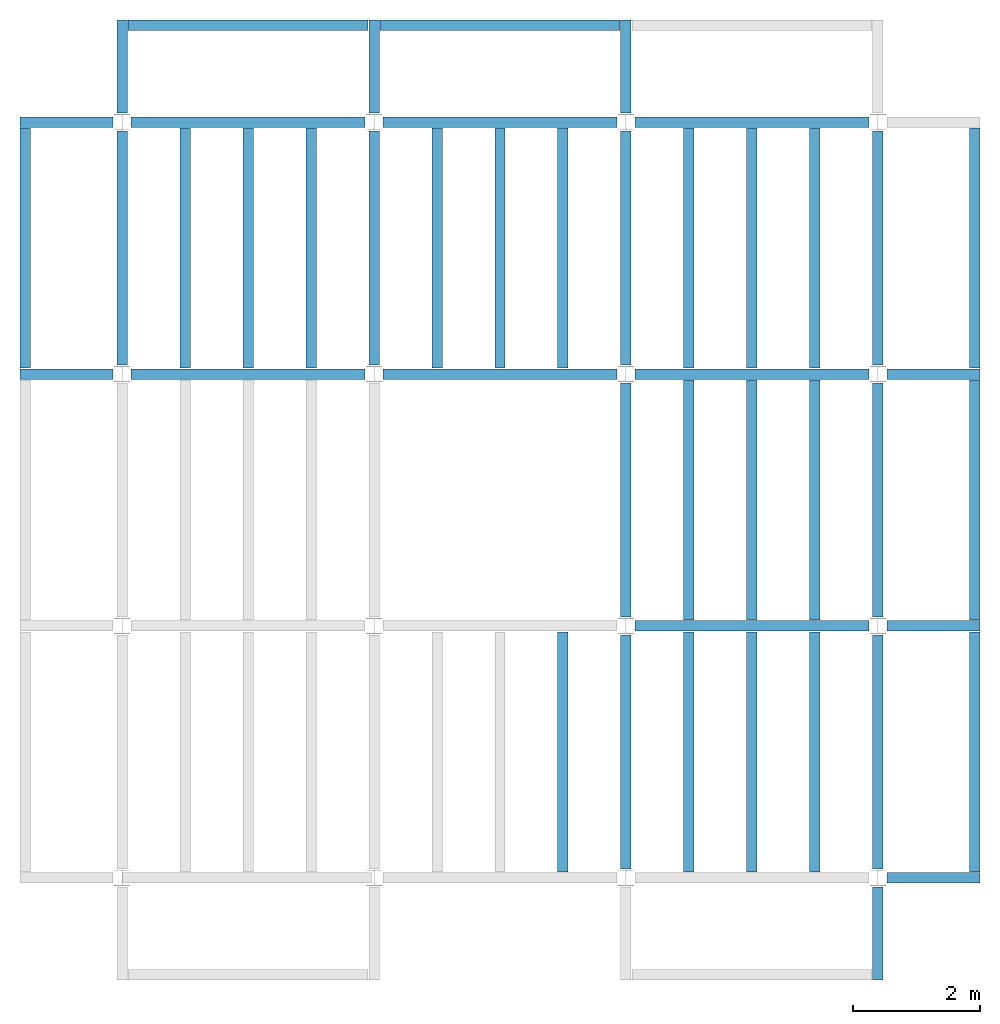
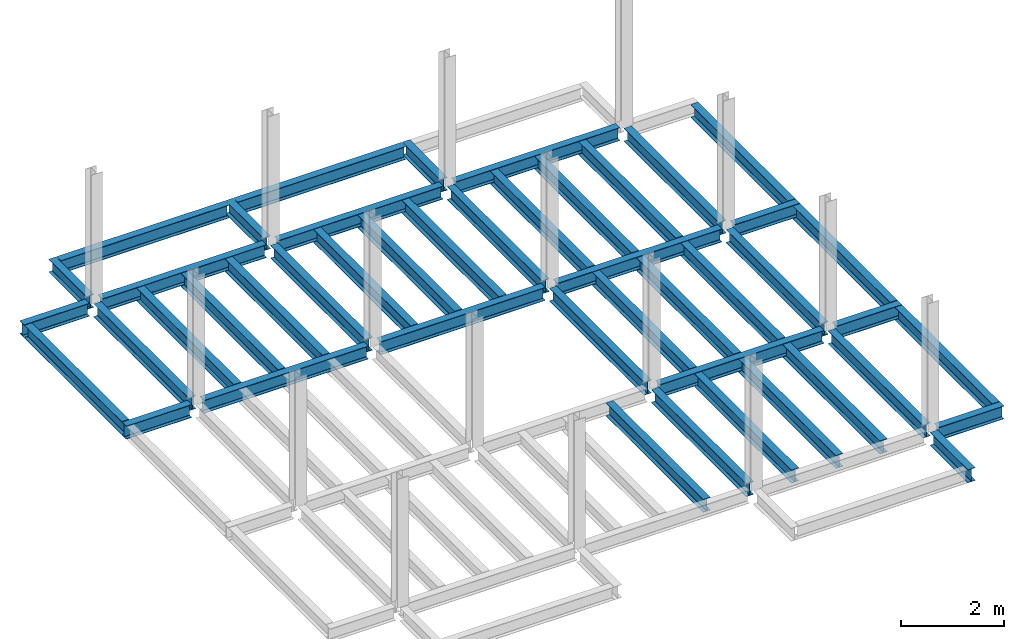
# One storey, part 2 of 3: 46 beams, 6 elements without a shape of their own.
"""IFC4 building model written with IfcOpenShell, lengths in feet."""

from ifc_helpers import new_model, entity, si_unit, converted_unit, derived_unit, direction, frame, origin, place, context, subcontext, project, spatial, line, arc, indexed_curve, outline, extrude, source, transform, mapped, material, type_object, type_shapes, element, aggregate, save


model = new_model("IFC4")

# Units and contexts
model_context = context("Model", 3, precision=0.0001, world=origin(), true_north=direction((6.123233995736766e-17, 1.0)))
plan_context = context("Plan", 3, precision=0.0001, world=origin(), true_north=direction((6.123233995736766e-17, 1.0)))
body_context = subcontext(model_context, "Body", "Model", "MODEL_VIEW")
ifc_project = project(units=[converted_unit("LENGTHUNIT", "FOOT", entity("IfcLengthMeasure", 0.3048), si_unit("LENGTHUNIT", "METRE"), dimensions=[1, 0, 0, 0, 0, 0, 0]), converted_unit("AREAUNIT", "SQUARE FOOT", entity("IfcAreaMeasure", 0.09290304), si_unit("AREAUNIT", "SQUARE_METRE"), dimensions=[2, 0, 0, 0, 0, 0, 0]), converted_unit("PLANEANGLEUNIT", "DEGREE", entity("IfcPlaneAngleMeasure", 0.017453292519943278), si_unit("PLANEANGLEUNIT", "RADIAN"), dimensions=[0, 0, 0, 0, 0, 0, 0]), converted_unit("VOLUMEUNIT", "CUBIC FOOT", entity("IfcVolumeMeasure", 0.028316846592000004), si_unit("VOLUMEUNIT", "CUBIC_METRE"), dimensions=[3, 0, 0, 0, 0, 0, 0]), si_unit("PRESSUREUNIT", "PASCAL"), derived_unit("MASSDENSITYUNIT", [(si_unit("MASSUNIT", "GRAM", prefix="KILO"), 1), (si_unit("LENGTHUNIT", "METRE"), -3)]), derived_unit("VAPORPERMEABILITYUNIT", [(si_unit("LENGTHUNIT", "METRE"), -1), (si_unit("TIMEUNIT", "SECOND"), 1)]), derived_unit("USERDEFINED", [(si_unit("MASSUNIT", "GRAM", prefix="KILO"), 1), (si_unit("LENGTHUNIT", "METRE"), 3), (si_unit("TIMEUNIT", "SECOND"), -3), (si_unit("ELECTRICCURRENTUNIT", "AMPERE"), -2)]), derived_unit("MODULUSOFELASTICITYUNIT", [(si_unit("MASSUNIT", "GRAM", prefix="KILO"), 1), (si_unit("LENGTHUNIT", "METRE"), -1), (si_unit("TIMEUNIT", "SECOND"), -2)]), derived_unit("THERMALEXPANSIONCOEFFICIENTUNIT", [(si_unit("THERMODYNAMICTEMPERATUREUNIT", "KELVIN"), -1)]), derived_unit("SPECIFICHEATCAPACITYUNIT", [(si_unit("TIMEUNIT", "SECOND"), -2), (si_unit("THERMODYNAMICTEMPERATUREUNIT", "KELVIN"), -1), (si_unit("LENGTHUNIT", "METRE"), 2)]), derived_unit("THERMALCONDUCTANCEUNIT", [(si_unit("MASSUNIT", "GRAM", prefix="KILO"), 1), (si_unit("TIMEUNIT", "SECOND"), -3), (si_unit("THERMODYNAMICTEMPERATUREUNIT", "KELVIN"), -1), (si_unit("LENGTHUNIT", "METRE"), 1)])], contexts=[model_context, plan_context])

# Site, building, storey
site_placement = place(None, origin())
site = spatial("IfcSite", under=ifc_project, at=site_placement, CompositionType="ELEMENT")
building_placement = place(site_placement, origin())
building = spatial("IfcBuilding", under=site, at=building_placement, CompositionType="ELEMENT")
storey_placement = place(building_placement, frame((0.0, 0.0, 119.875)))
storey = spatial("IfcBuildingStorey", under=building, at=storey_placement, Name="STR 13", CompositionType="ELEMENT", Elevation=119.875)

# Beams
ifc_material = material(Name="Steel ASTM A992", Category="Metal")
beam_type_1 = type_object("IfcBeamType", Name="W12X26", PredefinedType="JOIST", material=ifc_material)
shared_shape_1 = source(origin(), body_context, "Body", "SweptSolid", [
    extrude(outline(indexed_curve([(-0.27041666666666714, -0.47666666666666574), (-0.27041666666666714, -0.5083333333333351), (0.2704166666666669, -0.5083333333333351), (0.2704166666666669, -0.47666666666666574), (0.03458333333333309, -0.47666666666666574), (0.016905663803669493, -0.46934433619632937), (0.009583333333333202, -0.4516666666666659), (0.0095833333333332, 0.45166666666666705), (0.01690566380366948, 0.4693443361963307), (0.03458333333333325, 0.4766666666666671), (0.2704166666666669, 0.4766666666666671), (0.2704166666666669, 0.5083333333333312), (-0.2704166666666655, 0.5083333333333312), (-0.2704166666666655, 0.4766666666666671), (-0.034583333333333514, 0.47666666666666707), (-0.016905663803669865, 0.46934433619633054), (-0.009583333333333737, 0.45166666666666694), (-0.009583333333333735, -0.4516666666666658), (-0.01690566380367013, -0.4693443361963295), (-0.03458333333333368, -0.47666666666666574)], segments=[line(1, 2, 3, 4, 5), arc(5, 6, 7), line(7, 8), arc(8, 9, 10), line(10, 11, 12, 13, 14, 15), arc(15, 16, 17), line(17, 18), arc(18, 19, 20), line(20, 1)], self_intersect=False)), frame((-6.103346456692914, 0.0, 0.0), z_axis=(-1.0, 0.0, 0.0), x_axis=(0.0, -1.0, 0.0)), (0.0, 0.0, -1.0), 12.083333333333323),
])
type_shapes(beam_type_1, [shared_shape_1])
for number, where, name in (
    (1, (6.561679790026307, 39.0, -0.50833333333334), "W12X26"),
    (2, (6.561679790026288, 26.0, -0.50833333333334), "W12X26"),
):
    element("IfcBeam", number, at=place(storey_placement, frame(where)), inside=storey, type_object=beam_type_1, material=ifc_material, Name=name, ObjectType="W Shapes:W12X26", PredefinedType="JOIST", context=body_context, shape_type="MappedRepresentation", body=[
        mapped(shared_shape_1, transform((0.0, 0.0, 0.0), scale=1.0)),
    ])
for number, where, z_axis, x_axis, name in (
    (3, (39.0, 6.56167979002612, -0.50833333333334), (0.0, 0.0, 1.0), (0.0, 1.0, 0.0), "W12X26"),
    (4, (26.0, 6.561679790026162, -0.50833333333334), (0.0, 0.0, 1.0), (0.0, 1.0, 0.0), "W12X26"),
):
    element("IfcBeam", number, at=place(storey_placement, frame(where, z_axis=z_axis, x_axis=x_axis)), inside=storey, type_object=beam_type_1, material=ifc_material, Name=name, ObjectType="W Shapes:W12X26", PredefinedType="JOIST", context=body_context, shape_type="MappedRepresentation", body=[
        mapped(shared_shape_1, transform((0.0, 0.0, 0.0), scale=1.0)),
    ])
beam_type_2 = type_object("IfcBeamType", Name="W12X26", PredefinedType="JOIST", material=ifc_material)
shared_shape_2 = source(origin(), body_context, "Body", "SweptSolid", [
    extrude(outline(indexed_curve([(-0.27041666666666714, -0.47666666666666574), (-0.27041666666666714, -0.5083333333333351), (0.2704166666666669, -0.5083333333333351), (0.2704166666666669, -0.47666666666666574), (0.03458333333333309, -0.47666666666666574), (0.016905663803669493, -0.46934433619632937), (0.009583333333333202, -0.4516666666666659), (0.0095833333333332, 0.45166666666666705), (0.01690566380366948, 0.4693443361963307), (0.03458333333333325, 0.4766666666666671), (0.2704166666666669, 0.4766666666666671), (0.2704166666666669, 0.5083333333333312), (-0.2704166666666655, 0.5083333333333312), (-0.2704166666666655, 0.4766666666666671), (-0.034583333333333514, 0.47666666666666707), (-0.016905663803669865, 0.46934433619633054), (-0.009583333333333737, 0.45166666666666694), (-0.009583333333333735, -0.4516666666666658), (-0.01690566380367013, -0.4693443361963295), (-0.03458333333333368, -0.47666666666666574)], segments=[line(1, 2, 3, 4, 5), arc(5, 6, 7), line(7, 8), arc(8, 9, 10), line(10, 11, 12, 13, 14, 15), arc(15, 16, 17), line(17, 18), arc(18, 19, 20), line(20, 1)], self_intersect=False)), frame((-6.226706036745409, 0.0, 0.0), z_axis=(-1.0, 0.0, 0.0), x_axis=(0.0, -1.0, 0.0)), (0.0, 0.0, -1.0), 12.08333333333333),
])
type_shapes(beam_type_2, [shared_shape_2])
for number, where, name in (
    (5, (19.685039370078798, 39.0, -0.50833333333334), "W12X26"),
    (6, (19.68503937007878, 26.0, -0.50833333333334), "W12X26"),
):
    element("IfcBeam", number, at=place(storey_placement, frame(where)), inside=storey, type_object=beam_type_2, material=ifc_material, Name=name, ObjectType="W Shapes:W12X26", PredefinedType="JOIST", context=body_context, shape_type="MappedRepresentation", body=[
        mapped(shared_shape_2, transform((0.0, 0.0, 0.0), scale=1.0)),
    ])
for number, where, z_axis, x_axis, name in (
    (7, (39.0, 19.685039370078613, -0.50833333333334), (0.0, 0.0, 1.0), (0.0, 1.0, 0.0), "W12X26"),
    (8, (26.0, 19.685039370078655, -0.50833333333334), (0.0, 0.0, 1.0), (0.0, 1.0, 0.0), "W12X26"),
):
    element("IfcBeam", number, at=place(storey_placement, frame(where, z_axis=z_axis, x_axis=x_axis)), inside=storey, type_object=beam_type_2, material=ifc_material, Name=name, ObjectType="W Shapes:W12X26", PredefinedType="JOIST", context=body_context, shape_type="MappedRepresentation", body=[
        mapped(shared_shape_2, transform((0.0, 0.0, 0.0), scale=1.0)),
    ])

# Assembly, beams
assembly_1_placement = place(storey_placement, origin())
assembly_1 = element("IfcElementAssembly", 9, at=assembly_1_placement, inside=storey, Name="Structural Framing System", ObjectType="Structural Beam System:Structural Framing System", AssemblyPlace="NOTDEFINED", PredefinedType="BEAM_GRID")
beam_type_3 = type_object("IfcBeamType", Name="W12X26", PredefinedType="JOIST", material=ifc_material)
shared_shape_3 = source(origin(), body_context, "Body", "SweptSolid", [
    extrude(outline(indexed_curve([(-0.27041666666666714, -0.47666666666666574), (-0.27041666666666714, -0.5083333333333351), (0.2704166666666669, -0.5083333333333351), (0.2704166666666669, -0.47666666666666574), (0.03458333333333309, -0.47666666666666574), (0.016905663803669493, -0.46934433619632937), (0.009583333333333202, -0.4516666666666659), (0.0095833333333332, 0.45166666666666705), (0.01690566380366948, 0.4693443361963307), (0.03458333333333325, 0.4766666666666671), (0.2704166666666669, 0.4766666666666671), (0.2704166666666669, 0.5083333333333312), (-0.2704166666666655, 0.5083333333333312), (-0.2704166666666655, 0.4766666666666671), (-0.034583333333333514, 0.47666666666666707), (-0.016905663803669865, 0.46934433619633054), (-0.009583333333333737, 0.45166666666666694), (-0.009583333333333735, -0.4516666666666658), (-0.01690566380367013, -0.4693443361963295), (-0.03458333333333368, -0.47666666666666574)], segments=[line(1, 2, 3, 4, 5), arc(5, 6, 7), line(7, 8), arc(8, 9, 10), line(10, 11, 12, 13, 14, 15), arc(15, 16, 17), line(17, 18), arc(18, 19, 20), line(20, 1)], self_intersect=False)), frame((-6.187916666666566, 0.0, 0.0), z_axis=(-1.0, 0.0, 0.0), x_axis=(0.0, -1.0, 0.0)), (0.0, 0.0, -1.0), 12.375833333333075),
])
type_shapes(beam_type_3, [shared_shape_3])
beam_1_placement = place(assembly_1_placement, frame((3.250000000000073, 32.49999999999969, -0.50833333333334), z_axis=(0.0, 0.0, 1.0), x_axis=(0.0, 1.0, 0.0)))
beam_1 = element("IfcBeam", 10, at=beam_1_placement, type_object=beam_type_3, material=ifc_material, Name="W12X26", ObjectType="W Shapes:W12X26", PredefinedType="JOIST", context=body_context, shape_type="MappedRepresentation", body=[
    mapped(shared_shape_3, transform((0.0, 0.0, 0.0), scale=1.0)),
])
beam_2_placement = place(assembly_1_placement, frame((6.500000000000094, 32.49999999999967, -0.50833333333334), z_axis=(0.0, 0.0, 1.0), x_axis=(0.0, 1.0, 0.0)))
beam_2 = element("IfcBeam", 11, at=beam_2_placement, type_object=beam_type_3, material=ifc_material, Name="W12X26", ObjectType="W Shapes:W12X26", PredefinedType="JOIST", context=body_context, shape_type="MappedRepresentation", body=[
    mapped(shared_shape_3, transform((0.0, 0.0, 0.0), scale=1.0)),
])
beam_3_placement = place(assembly_1_placement, frame((9.750000000000115, 32.49999999999966, -0.50833333333334), z_axis=(0.0, 0.0, 1.0), x_axis=(0.0, 1.0, 0.0)))
beam_3 = element("IfcBeam", 12, at=beam_3_placement, type_object=beam_type_3, material=ifc_material, Name="W12X26", ObjectType="W Shapes:W12X26", PredefinedType="JOIST", context=body_context, shape_type="MappedRepresentation", body=[
    mapped(shared_shape_3, transform((0.0, 0.0, 0.0), scale=1.0)),
])
aggregate(assembly_1, [beam_1, beam_2, beam_3])

# Assembly, beam
assembly_2_placement = place(storey_placement, origin())
assembly_2 = element("IfcElementAssembly", 13, at=assembly_2_placement, inside=storey, Name="Structural Framing System", ObjectType="Structural Beam System:Structural Framing System", AssemblyPlace="NOTDEFINED", PredefinedType="BEAM_GRID")
beam_4_placement = place(assembly_2_placement, frame((22.750000000000107, 6.4999999999998, -0.50833333333334), z_axis=(0.0, 0.0, 1.0), x_axis=(0.0, 1.0, 0.0)))
beam_4 = element("IfcBeam", 14, at=beam_4_placement, type_object=beam_type_3, material=ifc_material, Name="W12X26", ObjectType="W Shapes:W12X26", PredefinedType="JOIST", context=body_context, shape_type="MappedRepresentation", body=[
    mapped(shared_shape_3, transform((0.0, 0.0, 0.0), scale=1.0)),
])
aggregate(assembly_2, [beam_4])

# Assembly, beams
assembly_3_placement = place(storey_placement, origin())
assembly_3 = element("IfcElementAssembly", 15, at=assembly_3_placement, inside=storey, Name="Structural Framing System", ObjectType="Structural Beam System:Structural Framing System", AssemblyPlace="NOTDEFINED", PredefinedType="BEAM_GRID")
beam_5_placement = place(assembly_3_placement, frame((16.25000000000014, 32.499999999999645, -0.50833333333334), z_axis=(0.0, 0.0, 1.0), x_axis=(0.0, 1.0, 0.0)))
beam_5 = element("IfcBeam", 16, at=beam_5_placement, type_object=beam_type_3, material=ifc_material, Name="W12X26", ObjectType="W Shapes:W12X26", PredefinedType="JOIST", context=body_context, shape_type="MappedRepresentation", body=[
    mapped(shared_shape_3, transform((0.0, 0.0, 0.0), scale=1.0)),
])
beam_6_placement = place(assembly_3_placement, frame((19.50000000000014, 32.49999999999963, -0.50833333333334), z_axis=(0.0, 0.0, 1.0), x_axis=(0.0, 1.0, 0.0)))
beam_6 = element("IfcBeam", 17, at=beam_6_placement, type_object=beam_type_3, material=ifc_material, Name="W12X26", ObjectType="W Shapes:W12X26", PredefinedType="JOIST", context=body_context, shape_type="MappedRepresentation", body=[
    mapped(shared_shape_3, transform((0.0, 0.0, 0.0), scale=1.0)),
])
beam_7_placement = place(assembly_3_placement, frame((22.750000000000142, 32.499999999999616, -0.50833333333334), z_axis=(0.0, 0.0, 1.0), x_axis=(0.0, 1.0, 0.0)))
beam_7 = element("IfcBeam", 18, at=beam_7_placement, type_object=beam_type_3, material=ifc_material, Name="W12X26", ObjectType="W Shapes:W12X26", PredefinedType="JOIST", context=body_context, shape_type="MappedRepresentation", body=[
    mapped(shared_shape_3, transform((0.0, 0.0, 0.0), scale=1.0)),
])
aggregate(assembly_3, [beam_5, beam_6, beam_7])

assembly_4_placement = place(storey_placement, origin())
assembly_4 = element("IfcElementAssembly", 19, at=assembly_4_placement, inside=storey, Name="Structural Framing System", ObjectType="Structural Beam System:Structural Framing System", AssemblyPlace="NOTDEFINED", PredefinedType="BEAM_GRID")
beam_8_placement = place(assembly_4_placement, frame((29.2500000000001, 6.49999999999975, -0.50833333333334), z_axis=(0.0, 0.0, 1.0), x_axis=(0.0, 1.0, 0.0)))
beam_8 = element("IfcBeam", 20, at=beam_8_placement, type_object=beam_type_3, material=ifc_material, Name="W12X26", ObjectType="W Shapes:W12X26", PredefinedType="JOIST", context=body_context, shape_type="MappedRepresentation", body=[
    mapped(shared_shape_3, transform((0.0, 0.0, 0.0), scale=1.0)),
])
beam_9_placement = place(assembly_4_placement, frame((32.5000000000001, 6.499999999999737, -0.50833333333334), z_axis=(0.0, 0.0, 1.0), x_axis=(0.0, 1.0, 0.0)))
beam_9 = element("IfcBeam", 21, at=beam_9_placement, type_object=beam_type_3, material=ifc_material, Name="W12X26", ObjectType="W Shapes:W12X26", PredefinedType="JOIST", context=body_context, shape_type="MappedRepresentation", body=[
    mapped(shared_shape_3, transform((0.0, 0.0, 0.0), scale=1.0)),
])
beam_10_placement = place(assembly_4_placement, frame((35.7500000000001, 6.499999999999728, -0.50833333333334), z_axis=(0.0, 0.0, 1.0), x_axis=(0.0, 1.0, 0.0)))
beam_10 = element("IfcBeam", 22, at=beam_10_placement, type_object=beam_type_3, material=ifc_material, Name="W12X26", ObjectType="W Shapes:W12X26", PredefinedType="JOIST", context=body_context, shape_type="MappedRepresentation", body=[
    mapped(shared_shape_3, transform((0.0, 0.0, 0.0), scale=1.0)),
])
aggregate(assembly_4, [beam_8, beam_9, beam_10])

assembly_5_placement = place(storey_placement, origin())
assembly_5 = element("IfcElementAssembly", 23, at=assembly_5_placement, inside=storey, Name="Structural Framing System", ObjectType="Structural Beam System:Structural Framing System", AssemblyPlace="NOTDEFINED", PredefinedType="BEAM_GRID")
beam_11_placement = place(assembly_5_placement, frame((29.25000000000012, 19.499999999999595, -0.50833333333334), z_axis=(0.0, 0.0, 1.0), x_axis=(0.0, 1.0, 0.0)))
beam_11 = element("IfcBeam", 24, at=beam_11_placement, type_object=beam_type_3, material=ifc_material, Name="W12X26", ObjectType="W Shapes:W12X26", PredefinedType="JOIST", context=body_context, shape_type="MappedRepresentation", body=[
    mapped(shared_shape_3, transform((0.0, 0.0, 0.0), scale=1.0)),
])
beam_12_placement = place(assembly_5_placement, frame((32.500000000000114, 19.49999999999958, -0.50833333333334), z_axis=(0.0, 0.0, 1.0), x_axis=(0.0, 1.0, 0.0)))
beam_12 = element("IfcBeam", 25, at=beam_12_placement, type_object=beam_type_3, material=ifc_material, Name="W12X26", ObjectType="W Shapes:W12X26", PredefinedType="JOIST", context=body_context, shape_type="MappedRepresentation", body=[
    mapped(shared_shape_3, transform((0.0, 0.0, 0.0), scale=1.0)),
])
beam_13_placement = place(assembly_5_placement, frame((35.750000000000114, 19.499999999999574, -0.50833333333334), z_axis=(0.0, 0.0, 1.0), x_axis=(0.0, 1.0, 0.0)))
beam_13 = element("IfcBeam", 26, at=beam_13_placement, type_object=beam_type_3, material=ifc_material, Name="W12X26", ObjectType="W Shapes:W12X26", PredefinedType="JOIST", context=body_context, shape_type="MappedRepresentation", body=[
    mapped(shared_shape_3, transform((0.0, 0.0, 0.0), scale=1.0)),
])
aggregate(assembly_5, [beam_11, beam_12, beam_13])

assembly_6_placement = place(storey_placement, origin())
assembly_6 = element("IfcElementAssembly", 27, at=assembly_6_placement, inside=storey, Name="Structural Framing System", ObjectType="Structural Beam System:Structural Framing System", AssemblyPlace="NOTDEFINED", PredefinedType="BEAM_GRID")
beam_14_placement = place(assembly_6_placement, frame((29.250000000000142, 32.4999999999996, -0.50833333333334), z_axis=(0.0, 0.0, 1.0), x_axis=(0.0, 1.0, 0.0)))
beam_14 = element("IfcBeam", 28, at=beam_14_placement, type_object=beam_type_3, material=ifc_material, Name="W12X26", ObjectType="W Shapes:W12X26", PredefinedType="JOIST", context=body_context, shape_type="MappedRepresentation", body=[
    mapped(shared_shape_3, transform((0.0, 0.0, 0.0), scale=1.0)),
])
beam_15_placement = place(assembly_6_placement, frame((32.50000000000014, 32.49999999999959, -0.50833333333334), z_axis=(0.0, 0.0, 1.0), x_axis=(0.0, 1.0, 0.0)))
beam_15 = element("IfcBeam", 29, at=beam_15_placement, type_object=beam_type_3, material=ifc_material, Name="W12X26", ObjectType="W Shapes:W12X26", PredefinedType="JOIST", context=body_context, shape_type="MappedRepresentation", body=[
    mapped(shared_shape_3, transform((0.0, 0.0, 0.0), scale=1.0)),
])
beam_16_placement = place(assembly_6_placement, frame((35.75000000000014, 32.499999999999574, -0.50833333333334), z_axis=(0.0, 0.0, 1.0), x_axis=(0.0, 1.0, 0.0)))
beam_16 = element("IfcBeam", 30, at=beam_16_placement, type_object=beam_type_3, material=ifc_material, Name="W12X26", ObjectType="W Shapes:W12X26", PredefinedType="JOIST", context=body_context, shape_type="MappedRepresentation", body=[
    mapped(shared_shape_3, transform((0.0, 0.0, 0.0), scale=1.0)),
])
aggregate(assembly_6, [beam_14, beam_15, beam_16])

# Beams
for number, where, z_axis, x_axis, name in (
    (31, (-5.0, 32.4999999999997, -0.50833333333334), (0.0, 0.0, 1.0), (0.0, 1.0, 0.0), "W12X26"),
    (32, (44.0, 6.4999999999997, -0.50833333333334), (0.0, 0.0, 1.0), (0.0, 1.0, 0.0), "W12X26"),
    (33, (44.0, 19.499999999999545, -0.50833333333334), (0.0, 0.0, 1.0), (0.0, 1.0, 0.0), "W12X26"),
    (34, (44.0, 32.499999999999545, -0.50833333333334), (0.0, 0.0, 1.0), (0.0, 1.0, 0.0), "W12X26"),
):
    element("IfcBeam", number, at=place(storey_placement, frame(where, z_axis=z_axis, x_axis=x_axis)), inside=storey, type_object=beam_type_3, material=ifc_material, Name=name, ObjectType="W Shapes:W12X26", PredefinedType="JOIST", context=body_context, shape_type="MappedRepresentation", body=[
        mapped(shared_shape_3, transform((0.0, 0.0, 0.0), scale=1.0)),
    ])
beam_17_placement = place(storey_placement, frame((6.5000000000001625, 44.0, -0.50833333333334)))
element("IfcBeam", 35, at=beam_17_placement, inside=storey, type_object=beam_type_3, material=ifc_material, Name="W Shapes:W12X26", ObjectType="W Shapes:W12X26", PredefinedType="JOIST", context=body_context, shape_type="MappedRepresentation", body=[
    mapped(shared_shape_3, transform((0.0, 0.0, 0.0), scale=1.0)),
])
beam_type_4 = type_object("IfcBeamType", Name="W12X26", PredefinedType="JOIST", material=ifc_material)
shared_shape_4 = source(origin(), body_context, "Body", "SweptSolid", [
    extrude(outline(indexed_curve([(-0.27041666666666714, -0.47666666666666574), (-0.27041666666666714, -0.5083333333333351), (0.2704166666666669, -0.5083333333333351), (0.2704166666666669, -0.47666666666666574), (0.03458333333333309, -0.47666666666666574), (0.016905663803669493, -0.46934433619632937), (0.009583333333333202, -0.4516666666666659), (0.0095833333333332, 0.45166666666666705), (0.01690566380366948, 0.4693443361963307), (0.03458333333333325, 0.4766666666666671), (0.2704166666666669, 0.4766666666666671), (0.2704166666666669, 0.5083333333333312), (-0.2704166666666655, 0.5083333333333312), (-0.2704166666666655, 0.4766666666666671), (-0.034583333333333514, 0.47666666666666707), (-0.016905663803669865, 0.46934433619633054), (-0.009583333333333737, 0.45166666666666694), (-0.009583333333333735, -0.4516666666666658), (-0.01690566380367013, -0.4693443361963295), (-0.03458333333333368, -0.47666666666666574)], segments=[line(1, 2, 3, 4, 5), arc(5, 6, 7), line(7, 8), arc(8, 9, 10), line(10, 11, 12, 13, 14, 15), arc(15, 16, 17), line(17, 18), arc(18, 19, 20), line(20, 1)], self_intersect=False)), frame((-6.165026246719308, 0.0, 0.0), z_axis=(-1.0, 0.0, 0.0), x_axis=(0.0, -1.0, 0.0)), (0.0, 0.0, -1.0), 12.08333333333334),
])
type_shapes(beam_type_4, [shared_shape_4])
for number, where, name in (
    (36, (32.6233595800526, 39.0, -0.50833333333334), "W12X26"),
    (37, (32.62335958005258, 26.0, -0.50833333333334), "W12X26"),
    (38, (32.62335958005255, 13.0, -0.50833333333334), "W12X26"),
):
    element("IfcBeam", number, at=place(storey_placement, frame(where)), inside=storey, type_object=beam_type_4, material=ifc_material, Name=name, ObjectType="W Shapes:W12X26", PredefinedType="JOIST", context=body_context, shape_type="MappedRepresentation", body=[
        mapped(shared_shape_4, transform((0.0, 0.0, 0.0), scale=1.0)),
    ])
for number, where, z_axis, x_axis, name in (
    (39, (39.0, 32.62335958005221, -0.50833333333334), (0.0, 0.0, 1.0), (0.0, 1.0, 0.0), "W12X26"),
    (40, (26.0, 32.62335958005225, -0.50833333333334), (0.0, 0.0, 1.0), (0.0, 1.0, 0.0), "W12X26"),
    (41, (13.0, 32.623359580052295, -0.50833333333334), (0.0, 0.0, 1.0), (0.0, 1.0, 0.0), "W12X26"),
    (42, (0.0, 32.62335958005234, -0.50833333333334), (0.0, 0.0, 1.0), (0.0, 1.0, 0.0), "W12X26"),
):
    element("IfcBeam", number, at=place(storey_placement, frame(where, z_axis=z_axis, x_axis=x_axis)), inside=storey, type_object=beam_type_4, material=ifc_material, Name=name, ObjectType="W Shapes:W12X26", PredefinedType="JOIST", context=body_context, shape_type="MappedRepresentation", body=[
        mapped(shared_shape_4, transform((0.0, 0.0, 0.0), scale=1.0)),
    ])
beam_type_5 = type_object("IfcBeamType", Name="W12X26", PredefinedType="JOIST", material=ifc_material)
shared_shape_5 = source(origin(), body_context, "Body", "SweptSolid", [
    extrude(outline(indexed_curve([(0.47666666666666574, -0.2704166666666672), (0.5083333333333351, -0.2704166666666672), (0.5083333333333351, 0.27041666666666686), (0.47666666666666574, 0.27041666666666686), (0.47666666666666574, 0.03458333333333307), (0.46934433619632937, 0.016905663803669473), (0.4516666666666659, 0.00958333333333318), (-0.45166666666666705, 0.00958333333333318), (-0.4693443361963307, 0.01690566380366946), (-0.4766666666666671, 0.03458333333333323), (-0.4766666666666671, 0.27041666666666686), (-0.5083333333333312, 0.27041666666666686), (-0.5083333333333312, -0.27041666666666553), (-0.4766666666666671, -0.27041666666666553), (-0.47666666666666707, -0.034583333333333535), (-0.46934433619633054, -0.016905663803669885), (-0.45166666666666694, -0.00958333333333376), (0.4516666666666658, -0.009583333333333756), (0.4693443361963295, -0.01690566380367015), (0.47666666666666574, -0.0345833333333337)], segments=[line(1, 2, 3, 4, 5), arc(5, 6, 7), line(7, 8), arc(8, 9, 10), line(10, 11, 12, 13, 14, 15), arc(15, 16, 17), line(17, 18), arc(18, 19, 20), line(20, 1)], self_intersect=False)), frame((-2.0416666666666208, 0.0, 0.0), z_axis=(1.0, 0.0, 0.0), x_axis=(0.0, 0.0, -1.0)), (0.0, 0.0, 1.0), 4.812083333333336),
])
type_shapes(beam_type_5, [shared_shape_5])
for number, where, z_axis, x_axis, name in (
    (43, (-2.4999999999998104, 39.0, -0.50833333333334), (0.0, 0.0, 1.0), (-1.0, 0.0, 0.0), "W12X26"),
    (44, (39.0, -2.50000000000058, -0.50833333333334), (0.0, 0.0, 1.0), (0.0, -1.0, 0.0), "W12X26"),
    (45, (-2.4999999999998317, 26.0, -0.50833333333334), (0.0, 0.0, 1.0), (-1.0, 0.0, 0.0), "W12X26"),
):
    element("IfcBeam", number, at=place(storey_placement, frame(where, z_axis=z_axis, x_axis=x_axis)), inside=storey, type_object=beam_type_5, material=ifc_material, Name=name, ObjectType="W Shapes:W12X26", PredefinedType="JOIST", context=body_context, shape_type="MappedRepresentation", body=[
        mapped(shared_shape_5, transform((0.0, 0.0, 0.0), scale=1.0)),
    ])
beam_type_6 = type_object("IfcBeamType", Name="W12X26", PredefinedType="JOIST", material=ifc_material)
shared_shape_6 = source(origin(), body_context, "Body", "SweptSolid", [
    extrude(outline(indexed_curve([(0.47666666666666574, -0.2704166666666672), (0.5083333333333351, -0.2704166666666672), (0.5083333333333351, 0.27041666666666686), (0.47666666666666574, 0.27041666666666686), (0.47666666666666574, 0.03458333333333307), (0.46934433619632937, 0.016905663803669473), (0.4516666666666659, 0.00958333333333318), (-0.45166666666666705, 0.00958333333333318), (-0.4693443361963307, 0.01690566380366946), (-0.4766666666666671, 0.03458333333333323), (-0.4766666666666671, 0.27041666666666686), (-0.5083333333333312, 0.27041666666666686), (-0.5083333333333312, -0.27041666666666553), (-0.4766666666666671, -0.27041666666666553), (-0.47666666666666707, -0.034583333333333535), (-0.46934433619633054, -0.016905663803669885), (-0.45166666666666694, -0.00958333333333376), (0.4516666666666658, -0.009583333333333756), (0.4693443361963295, -0.01690566380367015), (0.47666666666666574, -0.0345833333333337)], segments=[line(1, 2, 3, 4, 5), arc(5, 6, 7), line(7, 8), arc(8, 9, 10), line(10, 11, 12, 13, 14, 15), arc(15, 16, 17), line(17, 18), arc(18, 19, 20), line(20, 1)], self_intersect=False)), frame((-2.77041666666672, 0.0, 0.0), z_axis=(1.0, 0.0, 0.0), x_axis=(0.0, 0.0, -1.0)), (0.0, 0.0, 1.0), 4.812083333333389),
])
type_shapes(beam_type_6, [shared_shape_6])
for number, where, z_axis, x_axis, name in (
    (46, (41.50000000000013, 26.0, -0.50833333333334), (0.0, 0.0, 1.0), (-1.0, 0.0, 0.0), "W12X26"),
    (47, (41.50000000000011, 13.0, -0.50833333333334), (0.0, 0.0, 1.0), (-1.0, 0.0, 0.0), "W12X26"),
    (48, (41.500000000000085, 0.0, -0.50833333333334), (0.0, 0.0, 1.0), (-1.0, 0.0, 0.0), "W12X26"),
    (49, (13.0, 41.49999999999965, -0.50833333333334), (0.0, 0.0, 1.0), (0.0, -1.0, 0.0), "W12X26"),
    (50, (0.0, 41.499999999999694, -0.50833333333334), (0.0, 0.0, 1.0), (0.0, -1.0, 0.0), "W12X26"),
):
    element("IfcBeam", number, at=place(storey_placement, frame(where, z_axis=z_axis, x_axis=x_axis)), inside=storey, type_object=beam_type_6, material=ifc_material, Name=name, ObjectType="W Shapes:W12X26", PredefinedType="JOIST", context=body_context, shape_type="MappedRepresentation", body=[
        mapped(shared_shape_6, transform((0.0, 0.0, 0.0), scale=1.0)),
    ])
beam_type_7 = type_object("IfcBeamType", Name="W12X26", PredefinedType="JOIST", material=ifc_material)
shared_shape_7 = source(origin(), body_context, "Body", "SweptSolid", [
    extrude(outline(indexed_curve([(0.47666666666666574, -0.2704166666666672), (0.5083333333333351, -0.2704166666666672), (0.5083333333333351, 0.27041666666666686), (0.47666666666666574, 0.27041666666666686), (0.47666666666666574, 0.03458333333333307), (0.46934433619632937, 0.016905663803669473), (0.4516666666666659, 0.00958333333333318), (-0.45166666666666705, 0.00958333333333318), (-0.4693443361963307, 0.01690566380366946), (-0.4766666666666671, 0.03458333333333323), (-0.4766666666666671, 0.27041666666666686), (-0.5083333333333312, 0.27041666666666686), (-0.5083333333333312, -0.27041666666666553), (-0.4766666666666671, -0.27041666666666553), (-0.47666666666666707, -0.034583333333333535), (-0.46934433619633054, -0.016905663803669885), (-0.45166666666666694, -0.00958333333333376), (0.4516666666666658, -0.009583333333333756), (0.4693443361963295, -0.01690566380367015), (0.47666666666666574, -0.0345833333333337)], segments=[line(1, 2, 3, 4, 5), arc(5, 6, 7), line(7, 8), arc(8, 9, 10), line(10, 11, 12, 13, 14, 15), arc(15, 16, 17), line(17, 18), arc(18, 19, 20), line(20, 1)], self_intersect=False)), frame((-6.187916666666685, 0.0, 0.0), z_axis=(1.0, 0.0, 0.0), x_axis=(0.0, 0.0, -1.0)), (0.0, 0.0, 1.0), 12.375833333333318),
])
type_shapes(beam_type_7, [shared_shape_7])
beam_18_placement = place(storey_placement, frame((19.500000000000142, 44.0, -0.50833333333334), z_axis=(0.0, 0.0, 1.0), x_axis=(-1.0, 0.0, 0.0)))
element("IfcBeam", 51, at=beam_18_placement, inside=storey, type_object=beam_type_7, material=ifc_material, Name="W Shapes:W12X26", ObjectType="W Shapes:W12X26", PredefinedType="JOIST", context=body_context, shape_type="MappedRepresentation", body=[
    mapped(shared_shape_7, transform((0.0, 0.0, 0.0), scale=1.0)),
])
beam_type_8 = type_object("IfcBeamType", Name="W12X26", PredefinedType="JOIST", material=ifc_material)
shared_shape_8 = source(origin(), body_context, "Body", "SweptSolid", [
    extrude(outline(indexed_curve([(-0.2704166666666694, -0.50833333333334), (0.27041666666666586, -0.50833333333334), (0.2704166666666623, -0.4766666666666737), (0.034583333333333854, -0.4766666666666879), (0.016905663803669313, -0.4693443361963432), (0.009583333333335275, -0.4516666666666822), (0.009583333333335275, 0.4516666666666538), (0.016905663803669313, 0.46934433619631477), (0.034583333333333854, 0.47666666666665947), (0.2704166666666694, 0.47666666666665947), (0.27041666666666586, 0.5083333333333258), (-0.27041666666666586, 0.5083333333333258), (-0.27041666666666586, 0.47666666666665947), (-0.0345833333333303, 0.47666666666665947), (-0.01690566380366576, 0.46934433619631477), (-0.009583333333331723, 0.4516666666666538), (-0.009583333333331723, -0.4516666666666822), (-0.01690566380366576, -0.4693443361963432), (-0.034583333333333854, -0.4766666666666737), (-0.27041666666666586, -0.4766666666666737)], segments=[line(1, 2, 3, 4), arc(4, 5, 6), line(6, 7), arc(7, 8, 9), line(9, 10, 11, 12, 13, 14), arc(14, 15, 16), line(16, 17), arc(17, 18, 19), line(19, 20, 1)], self_intersect=False)), frame((26.0, 44.27041666666632, 119.36666666666663), z_axis=(0.0, -1.0, 0.0), x_axis=(-1.0, 0.0, 0.0)), (0.0, 0.0, 1.0), 4.812083333333393),
])
type_shapes(beam_type_8, [shared_shape_8])
beam_19_placement = place(storey_placement, frame((0.0, 0.0, -119.875)))
element("IfcBeam", 52, at=beam_19_placement, inside=storey, type_object=beam_type_8, material=ifc_material, Name="W12X26", ObjectType="W Shapes:W12X26", PredefinedType="JOIST", context=body_context, shape_type="MappedRepresentation", body=[
    mapped(shared_shape_8, transform((0.0, 0.0, 0.0), scale=1.0)),
])

save(model, "model.ifc")
